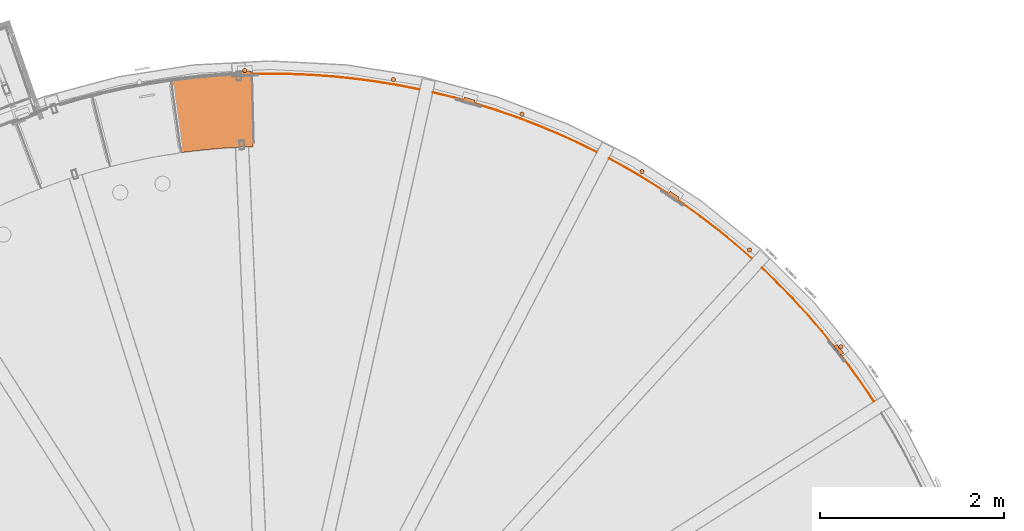
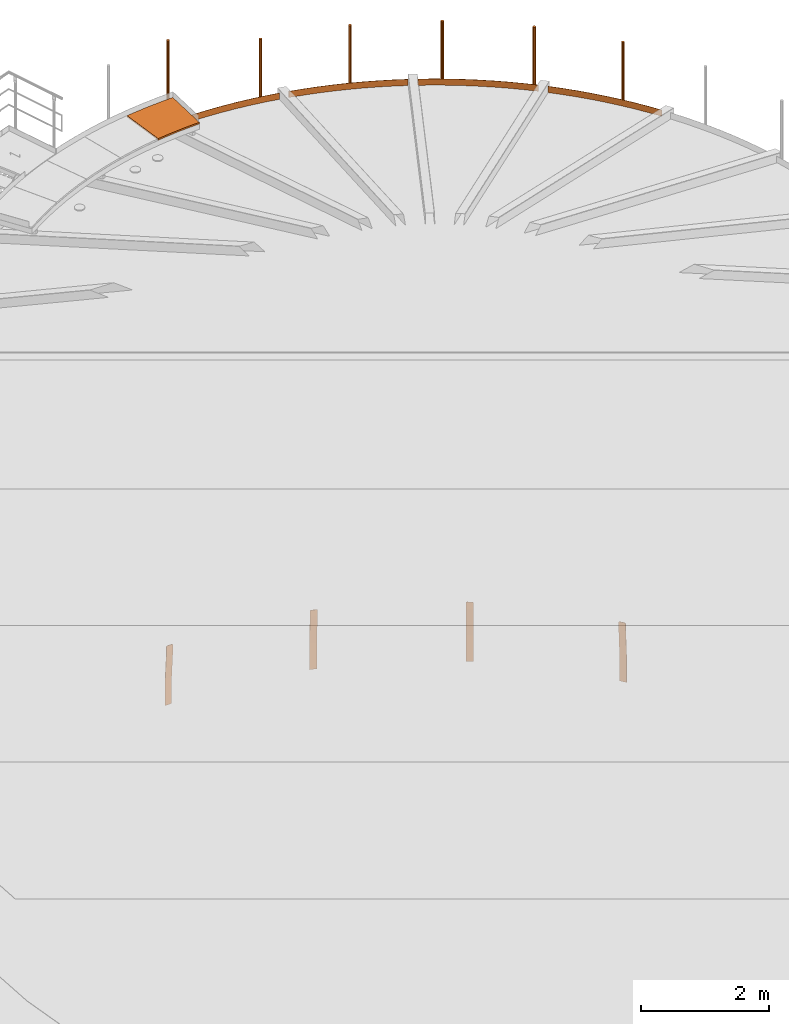
# One storey, part 41 of 126: 15 proxies.
"""IFC2X3 building model written with IfcOpenShell, lengths in millimetres."""

from ifc_helpers import new_model, si_unit, origin, origin_with_axes, place, context, project, spatial, faceted_brep, material, element, save


model = new_model("IFC2X3")

# Units and contexts
context_of_model_1 = context(None, 3, precision=0.1, world=origin())
context_of_model_2 = context(None, 3, precision=0.1, world=origin())
ifc_project = project(units=[si_unit("LENGTHUNIT", "METRE", prefix="MILLI"), si_unit("AREAUNIT", "SQUARE_METRE", prefix="CENTI"), si_unit("VOLUMEUNIT", "CUBIC_METRE", prefix="CENTI"), si_unit("MASSUNIT", "GRAM", prefix="KILO")], contexts=[context_of_model_1, context_of_model_2])

# Site, building, storey
site_placement = place(None, origin_with_axes())
site = spatial("IfcSite", under=ifc_project, at=site_placement, CompositionType="ELEMENT")
building_placement = place(site_placement, origin_with_axes())
building = spatial("IfcBuilding", under=site, at=building_placement, CompositionType="ELEMENT")
storey_placement = place(building_placement, origin_with_axes())
storey = spatial("IfcBuildingStorey", under=building, at=storey_placement, CompositionType="ELEMENT")

# Proxies
ifc_material = material(Name="STAHL")
proxy_1_placement = place(storey_placement, origin_with_axes())
element("IfcBuildingElementProxy", 1, at=proxy_1_placement, inside=storey, material=ifc_material, Name="profile", context=context_of_model_2, shape_type="Brep", body=[
    faceted_brep([(14213.8, 12784.0, 651.1), (14212.2, 12785.9, 654.1), (14205.9, 12781.0, 654.1), (14207.5, 12779.0, 651.1), (14214.9, 12782.5, 647.7), (14208.6, 12777.6, 647.7), (14215.6, 12781.6, 643.9), (14209.3, 12776.7, 643.9), (14209.5, 12776.4, 640.0), (14209.5, 12776.4, 540.0), (14239.5, 12799.8, 0.0), (14239.5, 12799.8, -500.0), (14245.8, 12804.7, -500.0), (14245.8, 12804.7, 0.0), (14215.8, 12781.3, 540.0), (14215.8, 12781.3, 640.0), (14137.7, 12868.3, 651.1), (14139.3, 12866.3, 654.1), (14145.6, 12871.2, 654.1), (14144.0, 12873.2, 651.1), (14142.9, 12874.7, 647.7), (14136.6, 12869.7, 647.7), (14142.2, 12875.6, 643.9), (14135.9, 12870.6, 643.9), (14142.0, 12875.9, 640.0), (14142.0, 12875.9, 540.0), (14171.9, 12899.3, 0.0), (14171.9, 12899.3, -500.0), (14165.6, 12894.3, -500.0), (14165.6, 12894.3, 0.0), (14135.7, 12870.9, 540.0), (14135.7, 12870.9, 640.0), (14199.6, 12789.1, 659.6), (14205.9, 12794.0, 659.6), (14203.5, 12797.1, 660.0), (14154.3, 12860.1, 660.0), (14151.9, 12863.2, 659.6), (14145.6, 12858.2, 659.6), (14148.0, 12855.2, 660.0), (14197.2, 12792.1, 660.0), (14149.6, 12866.1, 658.5), (14143.3, 12861.2, 658.5), (14147.4, 12868.9, 656.6), (14141.1, 12863.9, 656.6), (14201.9, 12786.1, 658.5), (14208.2, 12791.0, 658.5), (14204.1, 12783.4, 656.6), (14210.4, 12788.3, 656.6)], [[[0, 1, 2, 3]], [[4, 0, 3, 5]], [[6, 4, 5, 7]], [[8, 9, 10, 11, 12, 13, 14, 15, 6, 7]], [[16, 17, 18, 19]], [[16, 19, 20, 21]], [[21, 20, 22, 23]], [[23, 22, 24, 25, 26, 27, 28, 29, 30, 31]], [[32, 33, 34, 35, 36, 37, 38, 39]], [[37, 36, 40, 41]], [[41, 40, 42, 43]], [[43, 42, 18, 17]], [[33, 32, 44, 45]], [[45, 44, 46, 47]], [[47, 46, 2, 1]], [[15, 14, 13, 12, 27, 26, 25, 24, 22, 20, 19, 18, 42, 40, 36, 35, 34, 33, 45, 47, 1, 0, 4, 6]], [[9, 8, 7, 5, 3, 2, 46, 44, 32, 39, 38, 37, 41, 43, 17, 16, 21, 23, 31, 30, 29, 28, 11, 10]], [[28, 27, 12, 11]]]),
])
proxy_2_placement = place(storey_placement, origin_with_axes())
element("IfcBuildingElementProxy", 2, at=proxy_2_placement, inside=storey, material=ifc_material, Name="profile", context=context_of_model_2, shape_type="Brep", body=[
    faceted_brep([(12433.1, 14468.7, 651.1), (12431.0, 14470.1, 654.1), (12426.6, 14463.4, 654.1), (12428.6, 14462.0, 651.1), (12434.6, 14467.6, 647.7), (12430.2, 14461.0, 647.7), (12435.6, 14467.0, 643.9), (12431.1, 14460.4, 643.9), (12431.4, 14460.2, 640.0), (12431.4, 14460.2, 540.0), (12452.7, 14491.7, 0.0), (12452.7, 14491.7, -500.0), (12457.2, 14498.3, -500.0), (12457.2, 14498.3, 0.0), (12435.9, 14466.8, 540.0), (12435.9, 14466.8, 640.0), (12336.8, 14524.0, 654.1), (12341.3, 14530.6, 654.1), (12339.2, 14532.0, 651.1), (12334.7, 14525.4, 651.1), (12333.2, 14526.4, 647.7), (12337.7, 14533.0, 647.7), (12332.3, 14527.0, 643.9), (12336.7, 14533.7, 643.9), (12336.4, 14533.9, 640.0), (12336.4, 14533.9, 540.0), (12357.7, 14565.4, 0.0), (12357.7, 14565.4, -500.0), (12353.2, 14558.8, -500.0), (12353.2, 14558.8, 0.0), (12331.9, 14527.3, 540.0), (12331.9, 14527.3, 640.0), (12418.1, 14469.2, 659.6), (12422.6, 14475.8, 659.6), (12419.3, 14478.0, 660.0), (12353.0, 14522.7, 660.0), (12349.8, 14524.9, 659.6), (12345.3, 14518.3, 659.6), (12348.5, 14516.1, 660.0), (12414.8, 14471.3, 660.0), (12342.2, 14520.4, 658.5), (12346.7, 14527.0, 658.5), (12339.3, 14522.3, 656.6), (12343.8, 14528.9, 656.6), (12425.7, 14473.7, 658.5), (12421.2, 14467.1, 658.5), (12428.5, 14471.8, 656.6), (12424.1, 14465.1, 656.6)], [[[0, 1, 2, 3]], [[4, 0, 3, 5]], [[6, 4, 5, 7]], [[8, 9, 10, 11, 12, 13, 14, 15, 6, 7]], [[16, 17, 18, 19]], [[20, 19, 18, 21]], [[22, 20, 21, 23]], [[22, 23, 24, 25, 26, 27, 28, 29, 30, 31]], [[32, 33, 34, 35, 36, 37, 38, 39]], [[40, 37, 36, 41]], [[42, 40, 41, 43]], [[16, 42, 43, 17]], [[44, 33, 32, 45]], [[46, 44, 45, 47]], [[46, 47, 2, 1]], [[15, 14, 13, 12, 27, 26, 25, 24, 23, 21, 18, 17, 43, 41, 36, 35, 34, 33, 44, 46, 1, 0, 4, 6]], [[9, 8, 7, 5, 3, 2, 47, 45, 32, 39, 38, 37, 40, 42, 16, 19, 20, 22, 31, 30, 29, 28, 11, 10]], [[28, 27, 12, 11]]]),
])
proxy_3_placement = place(storey_placement, origin_with_axes())
element("IfcBuildingElementProxy", 3, at=proxy_3_placement, inside=storey, material=ifc_material, Name="profile", context=context_of_model_2, shape_type="Brep", body=[
    faceted_brep([(10216.6, 15521.4, 654.1), (10214.4, 15513.7, 654.1), (10216.8, 15513.0, 651.1), (10219.0, 15520.7, 651.1), (10218.6, 15512.5, 647.7), (10220.8, 15520.2, 647.7), (10219.7, 15512.2, 643.9), (10221.9, 15519.9, 643.9), (10220.0, 15512.1, 640.0), (10220.0, 15512.1, 540.0), (10230.5, 15548.6, 0.0), (10230.5, 15548.6, -500.0), (10232.7, 15556.3, -500.0), (10232.7, 15556.3, 0.0), (10222.2, 15519.7, 540.0), (10222.2, 15519.7, 640.0), (10110.3, 15543.5, 654.1), (10112.5, 15551.2, 654.1), (10110.1, 15551.9, 651.1), (10107.9, 15544.2, 651.1), (10106.1, 15544.7, 647.7), (10108.3, 15552.4, 647.7), (10105.0, 15545.0, 643.9), (10107.3, 15552.7, 643.9), (10106.9, 15552.8, 640.0), (10106.9, 15552.8, 540.0), (10117.4, 15589.4, 0.0), (10117.4, 15589.4, -500.0), (10115.2, 15581.7, -500.0), (10115.2, 15581.7, 0.0), (10104.7, 15545.1, 540.0), (10104.7, 15545.1, 640.0), (10204.6, 15516.5, 659.6), (10206.8, 15524.2, 659.6), (10203.0, 15525.3, 660.0), (10126.1, 15547.3, 660.0), (10122.4, 15548.4, 659.6), (10120.2, 15540.7, 659.6), (10123.9, 15539.6, 660.0), (10200.8, 15517.6, 660.0), (10118.8, 15549.4, 658.5), (10116.5, 15541.7, 658.5), (10115.4, 15550.4, 656.6), (10113.2, 15542.7, 656.6), (10208.2, 15515.5, 658.5), (10210.4, 15523.1, 658.5), (10211.5, 15514.5, 656.6), (10213.7, 15522.2, 656.6)], [[[0, 1, 2, 3]], [[3, 2, 4, 5]], [[5, 4, 6, 7]], [[8, 9, 10, 11, 12, 13, 14, 15, 7, 6]], [[16, 17, 18, 19]], [[20, 19, 18, 21]], [[22, 20, 21, 23]], [[22, 23, 24, 25, 26, 27, 28, 29, 30, 31]], [[32, 33, 34, 35, 36, 37, 38, 39]], [[37, 36, 40, 41]], [[41, 40, 42, 43]], [[43, 42, 17, 16]], [[33, 32, 44, 45]], [[45, 44, 46, 47]], [[0, 47, 46, 1]], [[15, 14, 13, 12, 27, 26, 25, 24, 23, 21, 18, 17, 42, 40, 36, 35, 34, 33, 45, 47, 0, 3, 5, 7]], [[9, 8, 6, 4, 2, 1, 46, 44, 32, 39, 38, 37, 41, 43, 16, 19, 20, 22, 31, 30, 29, 28, 11, 10]], [[27, 12, 11, 28]]]),
])
proxy_4_placement = place(storey_placement, origin_with_axes())
element("IfcBuildingElementProxy", 4, at=proxy_4_placement, inside=storey, material=ifc_material, Name="profile", context=context_of_model_2, shape_type="Brep", body=[
    faceted_brep([(7785.7, 15836.9, 654.1), (7786.0, 15828.9, 654.1), (7788.4, 15829.0, 651.1), (7788.2, 15837.0, 651.1), (7790.3, 15829.1, 647.7), (7790.0, 15837.1, 647.7), (7791.4, 15829.1, 643.9), (7791.1, 15837.1, 643.9), (7791.8, 15829.1, 640.0), (7791.8, 15829.1, 540.0), (7790.5, 15867.1, 0.0), (7790.5, 15867.1, -500.0), (7790.2, 15875.1, -500.0), (7790.2, 15875.1, 0.0), (7791.5, 15837.1, 540.0), (7791.5, 15837.1, 640.0), (7675.3, 15825.0, 651.1), (7677.7, 15825.1, 654.1), (7677.5, 15833.1, 654.1), (7675.0, 15833.0, 651.1), (7673.4, 15825.0, 647.7), (7673.1, 15833.0, 647.7), (7672.3, 15824.9, 643.9), (7672.0, 15832.9, 643.9), (7671.9, 15824.9, 540.0), (7671.9, 15824.9, 640.0), (7671.6, 15832.9, 640.0), (7671.6, 15832.9, 540.0), (7670.3, 15870.9, 0.0), (7670.3, 15870.9, -500.0), (7670.6, 15862.9, -500.0), (7670.6, 15862.9, 0.0), (7688.0, 15825.5, 659.6), (7691.9, 15825.6, 660.0), (7771.8, 15828.4, 660.0), (7775.7, 15828.6, 659.6), (7775.4, 15836.6, 659.6), (7771.5, 15836.4, 660.0), (7691.6, 15833.6, 660.0), (7687.7, 15833.5, 659.6), (7684.2, 15825.4, 658.5), (7683.9, 15833.4, 658.5), (7680.8, 15825.2, 656.6), (7680.5, 15833.2, 656.6), (7779.2, 15836.7, 658.5), (7779.5, 15828.7, 658.5), (7782.7, 15836.8, 656.6), (7782.9, 15828.8, 656.6)], [[[0, 1, 2, 3]], [[3, 2, 4, 5]], [[5, 4, 6, 7]], [[6, 8, 9, 10, 11, 12, 13, 14, 15, 7]], [[16, 17, 18, 19]], [[20, 16, 19, 21]], [[22, 20, 21, 23]], [[24, 25, 22, 23, 26, 27, 28, 29, 30, 31]], [[32, 33, 34, 35, 36, 37, 38, 39]], [[40, 32, 39, 41]], [[42, 40, 41, 43]], [[42, 43, 18, 17]], [[44, 36, 35, 45]], [[46, 44, 45, 47]], [[0, 46, 47, 1]], [[27, 26, 23, 21, 19, 18, 43, 41, 39, 38, 37, 36, 44, 46, 0, 3, 5, 7, 15, 14, 13, 12, 29, 28]], [[25, 24, 31, 30, 11, 10, 9, 8, 6, 4, 2, 1, 47, 45, 35, 34, 33, 32, 40, 42, 17, 16, 20, 22]], [[30, 29, 12, 11]]]),
])
proxy_5_placement = place(storey_placement, origin_with_axes())
element("IfcBuildingElementProxy", 5, at=proxy_5_placement, inside=storey, material=ifc_material, Name="profile", context=context_of_model_2, shape_type="Brep", body=[
    faceted_brep([(7752.9, 15881.0, 12185.2), (7752.9, 15881.0, 10955.2), (7751.8, 15886.7, 10955.2), (7751.8, 15886.7, 12185.2), (7749.3, 15892.0, 10955.2), (7749.3, 15892.0, 12185.2), (7745.7, 15896.5, 10955.2), (7745.7, 15896.5, 12185.2), (7741.1, 15900.1, 10955.2), (7741.1, 15900.1, 12185.2), (7735.7, 15902.4, 10955.2), (7735.7, 15902.4, 12185.2), (7730.0, 15903.4, 10955.2), (7730.0, 15903.4, 12185.2), (7724.2, 15903.0, 10955.2), (7724.2, 15903.0, 12185.2), (7718.7, 15901.2, 10955.2), (7718.7, 15901.2, 12185.2), (7713.7, 15898.2, 10955.2), (7713.7, 15898.2, 12185.2), (7709.6, 15894.0, 10955.2), (7709.6, 15894.0, 12185.2), (7706.7, 15889.0, 10955.2), (7706.7, 15889.0, 12185.2), (7705.0, 15883.4, 10955.2), (7705.0, 15883.4, 12185.2), (7704.7, 15877.6, 12185.2), (7704.7, 15877.6, 10955.2), (7705.8, 15871.9, 10955.2), (7705.8, 15871.9, 12185.2), (7708.2, 15866.6, 10955.2), (7708.2, 15866.6, 12185.2), (7711.9, 15862.1, 10955.2), (7711.9, 15862.1, 12185.2), (7716.5, 15858.5, 10955.2), (7716.5, 15858.5, 12185.2), (7721.8, 15856.2, 10955.2), (7721.8, 15856.2, 12185.2), (7727.5, 15855.2, 10955.2), (7727.5, 15855.2, 12185.2), (7733.4, 15855.6, 10955.2), (7733.4, 15855.6, 12185.2), (7738.9, 15857.4, 10955.2), (7738.9, 15857.4, 12185.2), (7743.9, 15860.4, 10955.2), (7743.9, 15860.4, 12185.2), (7747.9, 15864.6, 10955.2), (7747.9, 15864.6, 12185.2), (7750.9, 15869.6, 10955.2), (7750.9, 15869.6, 12185.2), (7752.6, 15875.2, 10955.2), (7752.6, 15875.2, 12185.2)], [[[0, 1, 2, 3]], [[3, 2, 4, 5]], [[5, 4, 6, 7]], [[7, 6, 8, 9]], [[9, 8, 10, 11]], [[11, 10, 12, 13]], [[13, 12, 14, 15]], [[15, 14, 16, 17]], [[17, 16, 18, 19]], [[19, 18, 20, 21]], [[21, 20, 22, 23]], [[23, 22, 24, 25]], [[26, 25, 24, 27]], [[26, 27, 28, 29]], [[29, 28, 30, 31]], [[31, 30, 32, 33]], [[33, 32, 34, 35]], [[35, 34, 36, 37]], [[37, 36, 38, 39]], [[39, 38, 40, 41]], [[41, 40, 42, 43]], [[43, 42, 44, 45]], [[45, 44, 46, 47]], [[47, 46, 48, 49]], [[49, 48, 50, 51]], [[51, 50, 1, 0]], [[39, 41, 43, 45, 47, 49, 51, 0, 3, 5, 7, 9, 11, 13, 15, 17, 19, 21, 23, 25, 26, 29, 31, 33, 35, 37]], [[38, 36, 34, 32, 30, 28, 27, 24, 22, 20, 18, 16, 14, 12, 10, 8, 6, 4, 2, 1, 50, 48, 46, 44, 42, 40]]]),
])
proxy_6_placement = place(storey_placement, origin_with_axes())
element("IfcBuildingElementProxy", 6, at=proxy_6_placement, inside=storey, material=ifc_material, Name="profile", context=context_of_model_2, shape_type="Brep", body=[
    faceted_brep([(14212.2, 12848.0, 11706.0), (14212.2, 12848.0, 10506.0), (14218.1, 12848.0, 10506.0), (14218.1, 12848.0, 11706.0), (14223.7, 12849.4, 10506.0), (14223.7, 12849.4, 11706.0), (14228.8, 12852.2, 10506.0), (14228.8, 12852.2, 11706.0), (14233.2, 12856.0, 10506.0), (14233.2, 12856.0, 11706.0), (14236.5, 12860.8, 10506.0), (14236.5, 12860.8, 11706.0), (14238.5, 12866.3, 10506.0), (14238.5, 12866.3, 11706.0), (14239.2, 12872.1, 10506.0), (14239.2, 12872.1, 11706.0), (14238.5, 12877.8, 10506.0), (14238.5, 12877.8, 11706.0), (14236.4, 12883.3, 10506.0), (14236.4, 12883.3, 11706.0), (14233.1, 12888.1, 10506.0), (14233.1, 12888.1, 11706.0), (14228.7, 12891.9, 10506.0), (14228.7, 12891.9, 11706.0), (14223.5, 12894.6, 10506.0), (14223.5, 12894.6, 11706.0), (14217.9, 12896.0, 11706.0), (14217.9, 12896.0, 10506.0), (14212.0, 12895.9, 10506.0), (14212.0, 12895.9, 11706.0), (14206.4, 12894.5, 10506.0), (14206.4, 12894.5, 11706.0), (14201.2, 12891.8, 10506.0), (14201.2, 12891.8, 11706.0), (14196.9, 12887.9, 10506.0), (14196.9, 12887.9, 11706.0), (14193.6, 12883.1, 10506.0), (14193.6, 12883.1, 11706.0), (14191.6, 12877.7, 10506.0), (14191.6, 12877.7, 11706.0), (14190.9, 12871.9, 10506.0), (14190.9, 12871.9, 11706.0), (14191.6, 12866.1, 10506.0), (14191.6, 12866.1, 11706.0), (14193.7, 12860.7, 10506.0), (14193.7, 12860.7, 11706.0), (14197.0, 12855.9, 10506.0), (14197.0, 12855.9, 11706.0), (14201.4, 12852.0, 10506.0), (14201.4, 12852.0, 11706.0), (14206.6, 12849.4, 10506.0), (14206.6, 12849.4, 11706.0)], [[[0, 1, 2, 3]], [[3, 2, 4, 5]], [[5, 4, 6, 7]], [[7, 6, 8, 9]], [[9, 8, 10, 11]], [[11, 10, 12, 13]], [[13, 12, 14, 15]], [[15, 14, 16, 17]], [[17, 16, 18, 19]], [[19, 18, 20, 21]], [[21, 20, 22, 23]], [[23, 22, 24, 25]], [[26, 25, 24, 27]], [[26, 27, 28, 29]], [[29, 28, 30, 31]], [[31, 30, 32, 33]], [[33, 32, 34, 35]], [[35, 34, 36, 37]], [[37, 36, 38, 39]], [[39, 38, 40, 41]], [[41, 40, 42, 43]], [[43, 42, 44, 45]], [[45, 44, 46, 47]], [[47, 46, 48, 49]], [[49, 48, 50, 51]], [[51, 50, 1, 0]], [[0, 3, 5, 7, 9, 11, 13, 15, 17, 19, 21, 23, 25, 26, 29, 31, 33, 35, 37, 39, 41, 43, 45, 47, 49, 51]], [[1, 50, 48, 46, 44, 42, 40, 38, 36, 34, 32, 30, 28, 27, 24, 22, 20, 18, 16, 14, 12, 10, 8, 6, 4, 2]]]),
])
proxy_7_placement = place(storey_placement, origin_with_axes())
element("IfcBuildingElementProxy", 7, at=proxy_7_placement, inside=storey, material=ifc_material, Name="profile", context=context_of_model_2, shape_type="Brep", body=[
    faceted_brep([(13228.1, 13902.1, 11706.0), (13222.4, 13901.0, 11706.0), (13222.4, 13901.0, 10506.0), (13228.1, 13902.1, 10506.0), (13233.4, 13904.5, 11706.0), (13233.4, 13904.5, 10506.0), (13238.0, 13908.1, 11706.0), (13238.0, 13908.1, 10506.0), (13241.5, 13912.7, 11706.0), (13241.5, 13912.7, 10506.0), (13243.9, 13918.1, 11706.0), (13243.9, 13918.1, 10506.0), (13244.9, 13923.8, 11706.0), (13244.9, 13923.8, 10506.0), (13244.5, 13929.6, 11706.0), (13244.5, 13929.6, 10506.0), (13242.7, 13935.2, 11706.0), (13242.7, 13935.2, 10506.0), (13239.7, 13940.1, 11706.0), (13239.7, 13940.1, 10506.0), (13235.6, 13944.2, 11706.0), (13235.6, 13944.2, 10506.0), (13230.6, 13947.2, 11706.0), (13230.6, 13947.2, 10506.0), (13225.0, 13948.9, 11706.0), (13225.0, 13948.9, 10506.0), (13219.2, 13949.2, 10506.0), (13219.2, 13949.2, 11706.0), (13213.5, 13948.1, 10506.0), (13213.5, 13948.1, 11706.0), (13208.2, 13945.7, 10506.0), (13208.2, 13945.7, 11706.0), (13203.6, 13942.1, 10506.0), (13203.6, 13942.1, 11706.0), (13200.0, 13937.5, 10506.0), (13200.0, 13937.5, 11706.0), (13197.7, 13932.1, 10506.0), (13197.7, 13932.1, 11706.0), (13196.7, 13926.4, 10506.0), (13196.7, 13926.4, 11706.0), (13197.1, 13920.6, 10506.0), (13197.1, 13920.6, 11706.0), (13198.8, 13915.0, 10506.0), (13198.8, 13915.0, 11706.0), (13201.9, 13910.1, 10506.0), (13201.9, 13910.1, 11706.0), (13206.0, 13906.0, 10506.0), (13206.0, 13906.0, 11706.0), (13211.0, 13903.0, 10506.0), (13211.0, 13903.0, 11706.0), (13216.6, 13901.3, 10506.0), (13216.6, 13901.3, 11706.0)], [[[0, 1, 2, 3]], [[4, 0, 3, 5]], [[6, 4, 5, 7]], [[8, 6, 7, 9]], [[10, 8, 9, 11]], [[12, 10, 11, 13]], [[14, 12, 13, 15]], [[16, 14, 15, 17]], [[18, 16, 17, 19]], [[20, 18, 19, 21]], [[22, 20, 21, 23]], [[24, 22, 23, 25]], [[24, 25, 26, 27]], [[27, 26, 28, 29]], [[29, 28, 30, 31]], [[31, 30, 32, 33]], [[33, 32, 34, 35]], [[35, 34, 36, 37]], [[37, 36, 38, 39]], [[39, 38, 40, 41]], [[41, 40, 42, 43]], [[43, 42, 44, 45]], [[45, 44, 46, 47]], [[47, 46, 48, 49]], [[49, 48, 50, 51]], [[51, 50, 2, 1]], [[1, 0, 4, 6, 8, 10, 12, 14, 16, 18, 20, 22, 24, 27, 29, 31, 33, 35, 37, 39, 41, 43, 45, 47, 49, 51]], [[2, 50, 48, 46, 44, 42, 40, 38, 36, 34, 32, 30, 28, 26, 25, 23, 21, 19, 17, 15, 13, 11, 9, 7, 5, 3]]]),
])
proxy_8_placement = place(storey_placement, origin_with_axes())
element("IfcBuildingElementProxy", 8, at=proxy_8_placement, inside=storey, material=ifc_material, Name="profile", context=context_of_model_2, shape_type="Brep", body=[
    faceted_brep([(12056.8, 14755.4, 11706.0), (12056.8, 14755.4, 10506.0), (12062.2, 14757.5, 10506.0), (12062.2, 14757.5, 11706.0), (12067.0, 14760.8, 10506.0), (12067.0, 14760.8, 11706.0), (12070.8, 14765.2, 10506.0), (12070.8, 14765.2, 11706.0), (12073.4, 14770.4, 10506.0), (12073.4, 14770.4, 11706.0), (12074.8, 14776.1, 10506.0), (12074.8, 14776.1, 11706.0), (12074.7, 14781.9, 10506.0), (12074.7, 14781.9, 11706.0), (12073.3, 14787.5, 10506.0), (12073.3, 14787.5, 11706.0), (12070.5, 14792.7, 10506.0), (12070.5, 14792.7, 11706.0), (12066.6, 14797.0, 10506.0), (12066.6, 14797.0, 11706.0), (12061.8, 14800.2, 10506.0), (12061.8, 14800.2, 11706.0), (12056.4, 14802.3, 10506.0), (12056.4, 14802.3, 11706.0), (12050.6, 14802.9, 10506.0), (12050.6, 14802.9, 11706.0), (12044.8, 14802.1, 10506.0), (12044.8, 14802.1, 11706.0), (12039.4, 14800.0, 11706.0), (12039.4, 14800.0, 10506.0), (12034.6, 14796.7, 10506.0), (12034.6, 14796.7, 11706.0), (12030.8, 14792.3, 10506.0), (12030.8, 14792.3, 11706.0), (12028.1, 14787.1, 10506.0), (12028.1, 14787.1, 11706.0), (12026.8, 14781.4, 10506.0), (12026.8, 14781.4, 11706.0), (12026.8, 14775.6, 10506.0), (12026.8, 14775.6, 11706.0), (12028.3, 14770.0, 10506.0), (12028.3, 14770.0, 11706.0), (12031.0, 14764.9, 10506.0), (12031.0, 14764.9, 11706.0), (12034.9, 14760.5, 10506.0), (12034.9, 14760.5, 11706.0), (12039.8, 14757.3, 10506.0), (12039.8, 14757.3, 11706.0), (12045.2, 14755.3, 10506.0), (12045.2, 14755.3, 11706.0), (12051.0, 14754.6, 10506.0), (12051.0, 14754.6, 11706.0)], [[[0, 1, 2, 3]], [[3, 2, 4, 5]], [[5, 4, 6, 7]], [[7, 6, 8, 9]], [[9, 8, 10, 11]], [[11, 10, 12, 13]], [[13, 12, 14, 15]], [[15, 14, 16, 17]], [[17, 16, 18, 19]], [[19, 18, 20, 21]], [[21, 20, 22, 23]], [[23, 22, 24, 25]], [[25, 24, 26, 27]], [[28, 27, 26, 29]], [[28, 29, 30, 31]], [[31, 30, 32, 33]], [[33, 32, 34, 35]], [[35, 34, 36, 37]], [[37, 36, 38, 39]], [[39, 38, 40, 41]], [[41, 40, 42, 43]], [[43, 42, 44, 45]], [[45, 44, 46, 47]], [[47, 46, 48, 49]], [[49, 48, 50, 51]], [[51, 50, 1, 0]], [[51, 0, 3, 5, 7, 9, 11, 13, 15, 17, 19, 21, 23, 25, 27, 28, 31, 33, 35, 37, 39, 41, 43, 45, 47, 49]], [[50, 48, 46, 44, 42, 40, 38, 36, 34, 32, 30, 29, 26, 24, 22, 20, 18, 16, 14, 12, 10, 8, 6, 4, 2, 1]]]),
])
proxy_9_placement = place(storey_placement, origin_with_axes())
element("IfcBuildingElementProxy", 9, at=proxy_9_placement, inside=storey, material=ifc_material, Name="profile", context=context_of_model_2, shape_type="Brep", body=[
    faceted_brep([(10754.6, 15382.2, 11706.0), (10754.6, 15382.2, 10506.0), (10759.6, 15385.3, 10506.0), (10759.6, 15385.3, 11706.0), (10763.6, 15389.5, 10506.0), (10763.6, 15389.5, 11706.0), (10766.6, 15394.5, 10506.0), (10766.6, 15394.5, 11706.0), (10768.3, 15400.1, 10506.0), (10768.3, 15400.1, 11706.0), (10768.5, 15405.9, 10506.0), (10768.5, 15405.9, 11706.0), (10767.4, 15411.6, 10506.0), (10767.4, 15411.6, 11706.0), (10765.0, 15416.9, 10506.0), (10765.0, 15416.9, 11706.0), (10761.3, 15421.4, 10506.0), (10761.3, 15421.4, 11706.0), (10756.7, 15425.0, 10506.0), (10756.7, 15425.0, 11706.0), (10751.4, 15427.3, 10506.0), (10751.4, 15427.3, 11706.0), (10745.6, 15428.3, 10506.0), (10745.6, 15428.3, 11706.0), (10739.8, 15427.9, 10506.0), (10739.8, 15427.9, 11706.0), (10734.3, 15426.1, 11706.0), (10734.3, 15426.1, 10506.0), (10729.3, 15423.0, 10506.0), (10729.3, 15423.0, 11706.0), (10725.3, 15418.8, 10506.0), (10725.3, 15418.8, 11706.0), (10722.3, 15413.8, 10506.0), (10722.3, 15413.8, 11706.0), (10720.7, 15408.2, 10506.0), (10720.7, 15408.2, 11706.0), (10720.4, 15402.4, 10506.0), (10720.4, 15402.4, 11706.0), (10721.5, 15396.7, 10506.0), (10721.5, 15396.7, 11706.0), (10723.9, 15391.4, 10506.0), (10723.9, 15391.4, 11706.0), (10727.6, 15386.9, 10506.0), (10727.6, 15386.9, 11706.0), (10732.2, 15383.3, 10506.0), (10732.2, 15383.3, 11706.0), (10737.5, 15381.0, 10506.0), (10737.5, 15381.0, 11706.0), (10743.3, 15380.0, 10506.0), (10743.3, 15380.0, 11706.0), (10749.1, 15380.5, 10506.0), (10749.1, 15380.5, 11706.0)], [[[0, 1, 2, 3]], [[3, 2, 4, 5]], [[5, 4, 6, 7]], [[7, 6, 8, 9]], [[9, 8, 10, 11]], [[11, 10, 12, 13]], [[13, 12, 14, 15]], [[15, 14, 16, 17]], [[17, 16, 18, 19]], [[19, 18, 20, 21]], [[21, 20, 22, 23]], [[23, 22, 24, 25]], [[26, 25, 24, 27]], [[26, 27, 28, 29]], [[29, 28, 30, 31]], [[31, 30, 32, 33]], [[33, 32, 34, 35]], [[35, 34, 36, 37]], [[37, 36, 38, 39]], [[39, 38, 40, 41]], [[41, 40, 42, 43]], [[43, 42, 44, 45]], [[45, 44, 46, 47]], [[47, 46, 48, 49]], [[49, 48, 50, 51]], [[51, 50, 1, 0]], [[49, 51, 0, 3, 5, 7, 9, 11, 13, 15, 17, 19, 21, 23, 25, 26, 29, 31, 33, 35, 37, 39, 41, 43, 45, 47]], [[48, 46, 44, 42, 40, 38, 36, 34, 32, 30, 28, 27, 24, 22, 20, 18, 16, 14, 12, 10, 8, 6, 4, 2, 1, 50]]]),
])
proxy_10_placement = place(storey_placement, origin_with_axes())
element("IfcBuildingElementProxy", 10, at=proxy_10_placement, inside=storey, material=ifc_material, Name="profile", context=context_of_model_2, shape_type="Brep", body=[
    faceted_brep([(9359.8, 15760.6, 11706.0), (9359.8, 15760.6, 10506.0), (9364.1, 15764.5, 10506.0), (9364.1, 15764.5, 11706.0), (9367.4, 15769.3, 10506.0), (9367.4, 15769.3, 11706.0), (9369.3, 15774.8, 10506.0), (9369.3, 15774.8, 11706.0), (9370.0, 15780.6, 10506.0), (9370.0, 15780.6, 11706.0), (9369.2, 15786.4, 10506.0), (9369.2, 15786.4, 11706.0), (9367.0, 15791.8, 10506.0), (9367.0, 15791.8, 11706.0), (9363.7, 15796.5, 10506.0), (9363.7, 15796.5, 11706.0), (9359.3, 15800.3, 10506.0), (9359.3, 15800.3, 11706.0), (9354.1, 15802.9, 10506.0), (9354.1, 15802.9, 11706.0), (9348.4, 15804.2, 10506.0), (9348.4, 15804.2, 11706.0), (9342.6, 15804.2, 10506.0), (9342.6, 15804.2, 11706.0), (9336.9, 15802.7, 10506.0), (9336.9, 15802.7, 11706.0), (9331.8, 15799.9, 10506.0), (9331.8, 15799.9, 11706.0), (9327.5, 15796.0, 11706.0), (9327.5, 15796.0, 10506.0), (9324.3, 15791.2, 10506.0), (9324.3, 15791.2, 11706.0), (9322.3, 15785.7, 10506.0), (9322.3, 15785.7, 11706.0), (9321.7, 15779.9, 10506.0), (9321.7, 15779.9, 11706.0), (9322.5, 15774.1, 10506.0), (9322.5, 15774.1, 11706.0), (9324.6, 15768.7, 10506.0), (9324.6, 15768.7, 11706.0), (9328.0, 15764.0, 10506.0), (9328.0, 15764.0, 11706.0), (9332.4, 15760.2, 10506.0), (9332.4, 15760.2, 11706.0), (9337.6, 15757.5, 10506.0), (9337.6, 15757.5, 11706.0), (9343.3, 15756.2, 10506.0), (9343.3, 15756.2, 11706.0), (9349.1, 15756.3, 10506.0), (9349.1, 15756.3, 11706.0), (9354.7, 15757.8, 10506.0), (9354.7, 15757.8, 11706.0)], [[[0, 1, 2, 3]], [[3, 2, 4, 5]], [[5, 4, 6, 7]], [[7, 6, 8, 9]], [[9, 8, 10, 11]], [[11, 10, 12, 13]], [[13, 12, 14, 15]], [[15, 14, 16, 17]], [[17, 16, 18, 19]], [[19, 18, 20, 21]], [[21, 20, 22, 23]], [[23, 22, 24, 25]], [[25, 24, 26, 27]], [[28, 27, 26, 29]], [[28, 29, 30, 31]], [[31, 30, 32, 33]], [[33, 32, 34, 35]], [[35, 34, 36, 37]], [[37, 36, 38, 39]], [[39, 38, 40, 41]], [[41, 40, 42, 43]], [[43, 42, 44, 45]], [[45, 44, 46, 47]], [[47, 46, 48, 49]], [[49, 48, 50, 51]], [[51, 50, 1, 0]], [[47, 49, 51, 0, 3, 5, 7, 9, 11, 13, 15, 17, 19, 21, 23, 25, 27, 28, 31, 33, 35, 37, 39, 41, 43, 45]], [[46, 44, 42, 40, 38, 36, 34, 32, 30, 29, 26, 24, 22, 20, 18, 16, 14, 12, 10, 8, 6, 4, 2, 1, 50, 48]]]),
])
proxy_11_placement = place(storey_placement, origin_with_axes())
element("IfcBuildingElementProxy", 11, at=proxy_11_placement, inside=storey, material=ifc_material, Name="profile", context=context_of_model_2, shape_type="Brep", body=[
    faceted_brep([(14577.3, 12279.2, 10636.0), (14577.3, 12279.2, 10516.0), (14444.5, 12476.6, 10516.0), (14305.9, 12670.0, 10516.0), (14161.4, 12859.0, 10516.0), (14011.3, 13043.6, 10516.0), (13855.7, 13223.5, 10516.0), (13694.6, 13398.7, 10516.0), (13528.3, 13568.8, 10516.0), (13357.0, 13733.9, 10516.0), (13357.0, 13733.9, 10636.0), (13528.3, 13568.8, 10636.0), (13694.6, 13398.7, 10636.0), (13855.7, 13223.5, 10636.0), (14011.3, 13043.6, 10636.0), (14161.4, 12859.0, 10636.0), (14305.9, 12670.0, 10636.0), (14444.5, 12476.6, 10636.0), (14573.1, 12276.5, 10636.0), (13353.5, 13730.2, 10636.0), (13524.8, 13565.3, 10636.0), (13691.0, 13395.2, 10636.0), (13851.9, 13220.2, 10636.0), (14007.5, 13040.4, 10636.0), (14157.5, 12855.9, 10636.0), (14301.9, 12667.0, 10636.0), (14440.4, 12473.8, 10636.0), (13353.5, 13730.2, 10516.0), (13524.8, 13565.3, 10516.0), (13691.0, 13395.2, 10516.0), (13851.9, 13220.2, 10516.0), (14007.5, 13040.4, 10516.0), (14157.5, 12855.9, 10516.0), (14301.9, 12667.0, 10516.0), (14440.4, 12473.8, 10516.0), (14573.1, 12276.5, 10516.0)], [[[0, 1, 2, 3, 4, 5, 6, 7, 8, 9, 10, 11, 12, 13, 14, 15, 16, 17]], [[18, 0, 17, 16, 15, 14, 13, 12, 11, 10, 19, 20, 21, 22, 23, 24, 25, 26]], [[18, 26, 25, 24, 23, 22, 21, 20, 19, 27, 28, 29, 30, 31, 32, 33, 34, 35]], [[35, 34, 33, 32, 31, 30, 29, 28, 27, 9, 8, 7, 6, 5, 4, 3, 2, 1]], [[19, 10, 9, 27]], [[18, 35, 1, 0]]]),
])
proxy_12_placement = place(storey_placement, origin_with_axes())
element("IfcBuildingElementProxy", 12, at=proxy_12_placement, inside=storey, material=ifc_material, Name="profile", context=context_of_model_2, shape_type="Brep", body=[
    faceted_brep([(13247.1, 13834.6, 10636.0), (13247.1, 13834.6, 10516.0), (13067.8, 13990.9, 10516.0), (12883.8, 14141.8, 10516.0), (12695.3, 14287.0, 10516.0), (12502.6, 14426.5, 10516.0), (12305.6, 14560.0, 10516.0), (12104.8, 14687.5, 10516.0), (11900.1, 14808.8, 10516.0), (11691.9, 14923.8, 10516.0), (11691.9, 14923.8, 10636.0), (11900.1, 14808.8, 10636.0), (12104.8, 14687.5, 10636.0), (12305.6, 14560.0, 10636.0), (12502.6, 14426.5, 10636.0), (12695.3, 14287.0, 10636.0), (12883.8, 14141.8, 10636.0), (13067.8, 13990.9, 10636.0), (13243.7, 13830.8, 10636.0), (11689.5, 14919.4, 10636.0), (11897.6, 14804.4, 10636.0), (12102.1, 14683.2, 10636.0), (12302.9, 14555.8, 10636.0), (12499.7, 14422.4, 10636.0), (12692.4, 14283.0, 10636.0), (12880.7, 14137.9, 10636.0), (13064.5, 13987.1, 10636.0), (11689.5, 14919.4, 10516.0), (11897.6, 14804.4, 10516.0), (12102.1, 14683.2, 10516.0), (12302.9, 14555.8, 10516.0), (12499.7, 14422.4, 10516.0), (12692.4, 14283.0, 10516.0), (12880.7, 14137.9, 10516.0), (13064.5, 13987.1, 10516.0), (13243.7, 13830.8, 10516.0)], [[[0, 1, 2, 3, 4, 5, 6, 7, 8, 9, 10, 11, 12, 13, 14, 15, 16, 17]], [[18, 0, 17, 16, 15, 14, 13, 12, 11, 10, 19, 20, 21, 22, 23, 24, 25, 26]], [[18, 26, 25, 24, 23, 22, 21, 20, 19, 27, 28, 29, 30, 31, 32, 33, 34, 35]], [[35, 34, 33, 32, 31, 30, 29, 28, 27, 9, 8, 7, 6, 5, 4, 3, 2, 1]], [[19, 10, 9, 27]], [[18, 35, 1, 0]]]),
])
proxy_13_placement = place(storey_placement, origin_with_axes())
element("IfcBuildingElementProxy", 13, at=proxy_13_placement, inside=storey, material=ifc_material, Name="profile", context=context_of_model_2, shape_type="Brep", body=[
    faceted_brep([(11559.7, 14992.7, 10636.0), (11559.7, 14992.7, 10516.0), (11346.0, 15097.3, 10516.0), (11129.2, 15195.4, 10516.0), (10909.6, 15286.9, 10516.0), (10687.3, 15371.7, 10516.0), (10462.6, 15449.7, 10516.0), (10235.5, 15520.9, 10516.0), (10006.4, 15585.1, 10516.0), (9775.5, 15642.3, 10516.0), (9775.5, 15642.3, 10636.0), (10006.4, 15585.1, 10636.0), (10235.5, 15520.9, 10636.0), (10462.6, 15449.7, 10636.0), (10687.3, 15371.7, 10636.0), (10909.6, 15286.9, 10636.0), (11129.2, 15195.4, 10636.0), (11346.0, 15097.3, 10636.0), (11557.4, 14988.2, 10636.0), (9774.4, 15637.4, 10636.0), (10005.2, 15580.2, 10636.0), (10234.1, 15516.1, 10636.0), (10461.0, 15445.0, 10636.0), (10685.6, 15367.0, 10636.0), (10907.8, 15282.3, 10636.0), (11127.3, 15190.9, 10636.0), (11343.9, 15092.8, 10636.0), (11557.4, 14988.2, 10516.0), (9774.4, 15637.4, 10516.0), (10005.2, 15580.2, 10516.0), (10234.1, 15516.1, 10516.0), (10461.0, 15445.0, 10516.0), (10685.6, 15367.0, 10516.0), (10907.8, 15282.3, 10516.0), (11127.3, 15190.9, 10516.0), (11343.9, 15092.8, 10516.0)], [[[0, 1, 2, 3, 4, 5, 6, 7, 8, 9, 10, 11, 12, 13, 14, 15, 16, 17]], [[18, 0, 17, 16, 15, 14, 13, 12, 11, 10, 19, 20, 21, 22, 23, 24, 25, 26]], [[27, 18, 26, 25, 24, 23, 22, 21, 20, 19, 28, 29, 30, 31, 32, 33, 34, 35]], [[27, 35, 34, 33, 32, 31, 30, 29, 28, 9, 8, 7, 6, 5, 4, 3, 2, 1]], [[19, 10, 9, 28]], [[18, 27, 1, 0]]]),
])
proxy_14_placement = place(storey_placement, origin_with_axes())
element("IfcBuildingElementProxy", 14, at=proxy_14_placement, inside=storey, material=ifc_material, Name="profile", context=context_of_model_2, shape_type="Brep", body=[
    faceted_brep([(9630.0, 15674.6, 10636.0), (9630.0, 15674.6, 10516.0), (9396.5, 15720.4, 10516.0), (9161.8, 15759.0, 10516.0), (8925.9, 15790.6, 10516.0), (8689.3, 15814.9, 10516.0), (8452.0, 15832.1, 10516.0), (8214.3, 15842.1, 10516.0), (7976.4, 15844.8, 10516.0), (7738.5, 15840.3, 10516.0), (7738.5, 15840.3, 10636.0), (7976.4, 15844.8, 10636.0), (8214.3, 15842.1, 10636.0), (8452.0, 15832.1, 10636.0), (8689.3, 15814.9, 10636.0), (8925.9, 15790.6, 10636.0), (9161.8, 15759.0, 10636.0), (9396.5, 15720.4, 10636.0), (9629.0, 15669.7, 10636.0), (7738.7, 15835.3, 10636.0), (7976.4, 15839.8, 10636.0), (8214.1, 15837.1, 10636.0), (8451.7, 15827.1, 10636.0), (8688.8, 15810.0, 10636.0), (8925.4, 15785.6, 10636.0), (9161.0, 15754.1, 10636.0), (9395.6, 15715.5, 10636.0), (9629.0, 15669.7, 10516.0), (7738.7, 15835.3, 10516.0), (7976.4, 15839.8, 10516.0), (8214.1, 15837.1, 10516.0), (8451.7, 15827.1, 10516.0), (8688.8, 15810.0, 10516.0), (8925.4, 15785.6, 10516.0), (9161.0, 15754.1, 10516.0), (9395.6, 15715.5, 10516.0)], [[[0, 1, 2, 3, 4, 5, 6, 7, 8, 9, 10, 11, 12, 13, 14, 15, 16, 17]], [[18, 0, 17, 16, 15, 14, 13, 12, 11, 10, 19, 20, 21, 22, 23, 24, 25, 26]], [[27, 18, 26, 25, 24, 23, 22, 21, 20, 19, 28, 29, 30, 31, 32, 33, 34, 35]], [[27, 35, 34, 33, 32, 31, 30, 29, 28, 9, 8, 7, 6, 5, 4, 3, 2, 1]], [[10, 9, 28, 19]], [[0, 18, 27, 1]]]),
])
proxy_15_placement = place(storey_placement, origin_with_axes())
element("IfcBuildingElementProxy", 15, at=proxy_15_placement, inside=storey, material=ifc_material, Name="profile", context=context_of_model_2, shape_type="Brep", body=[
    faceted_brep([(7038.4, 14985.4, 11085.2), (7038.4, 14985.4, 11055.2), (7193.8, 15005.2, 11055.2), (7349.6, 15021.5, 11055.2), (7505.7, 15034.3, 11055.2), (7662.0, 15043.6, 11055.2), (7818.5, 15049.5, 11055.2), (7818.5, 15049.5, 11085.2), (7662.0, 15043.6, 11085.2), (7505.7, 15034.3, 11085.2), (7349.6, 15021.5, 11085.2), (7193.8, 15005.2, 11085.2), (6929.0, 15773.8, 11085.2), (6929.0, 15773.8, 11055.2), (7102.0, 15795.8, 11085.2), (7275.5, 15814.0, 11085.2), (7449.3, 15828.3, 11085.2), (7623.4, 15838.7, 11085.2), (7797.7, 15845.3, 11085.2), (7797.7, 15845.3, 11055.2), (7623.4, 15838.7, 11055.2), (7449.3, 15828.3, 11055.2), (7275.5, 15814.0, 11055.2), (7102.0, 15795.8, 11055.2)], [[[0, 1, 2, 3, 4, 5, 6, 7, 8, 9, 10, 11]], [[0, 12, 13, 1]], [[13, 12, 14, 15, 16, 17, 18, 19, 20, 21, 22, 23]], [[18, 7, 6, 19]], [[0, 11, 10, 9, 8, 7, 18, 17, 16, 15, 14, 12]], [[1, 13, 23, 22, 21, 20, 19, 6, 5, 4, 3, 2]]]),
])

save(model, "model.ifc")
